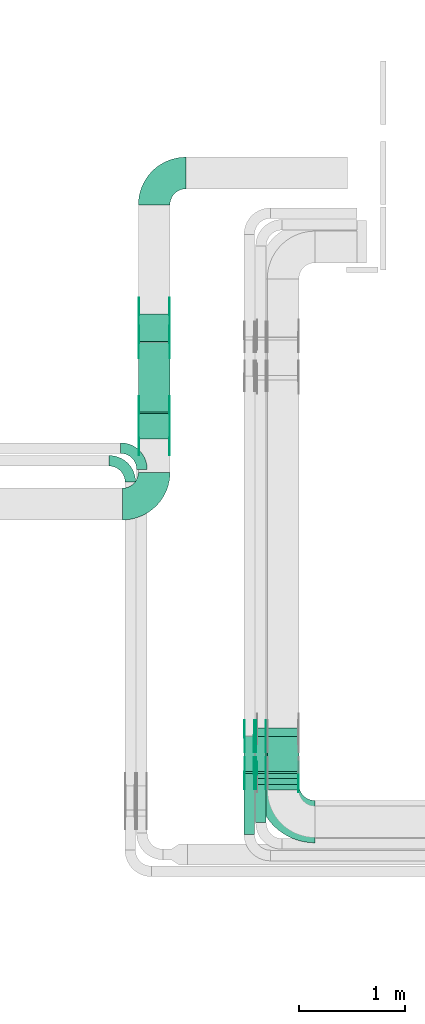
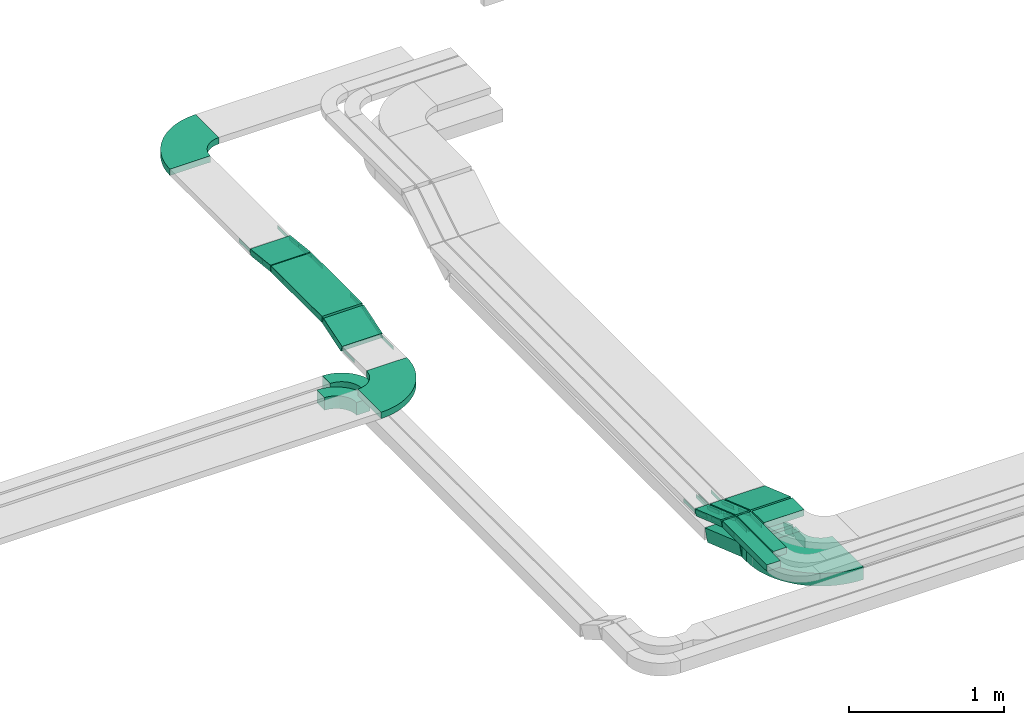
# One storey, part 7 of 28: 40 flow fittings, 11 flow segments.
"""IFC2X3 building model written with IfcOpenShell, lengths in millimetres."""

from ifc_helpers import new_model, entity, si_unit, converted_unit, derived_unit, direction, frame, frame_2d, origin, origin_2d_with_axis, place, context, subcontext, project, spatial, polyline, circle_curve, parameter, trimmed, segment, composite_curve, rectangle, outline, extrude, source, transform, mapped, material, type_object, type_shapes, element, save


model = new_model("IFC2X3")

# Units and contexts
model_context = context("Model", 3, precision=0.01, world=origin(), true_north=direction((6.12303176911189e-17, 1.0)))
body_context = subcontext(model_context, "Body", "Model", "MODEL_VIEW")
ifc_project = project(units=[si_unit("LENGTHUNIT", "METRE", prefix="MILLI"), si_unit("AREAUNIT", "SQUARE_METRE"), si_unit("VOLUMEUNIT", "CUBIC_METRE"), converted_unit("PLANEANGLEUNIT", "DEGREE", entity("IfcRatioMeasure", 0.0174532925199433), si_unit("PLANEANGLEUNIT", "RADIAN"), dimensions=[0, 0, 0, 0, 0, 0, 0]), si_unit("MASSUNIT", "GRAM", prefix="KILO"), derived_unit("MASSDENSITYUNIT", [(si_unit("MASSUNIT", "GRAM", prefix="KILO"), 1), (si_unit("LENGTHUNIT", "METRE"), -3)]), derived_unit("MOMENTOFINERTIAUNIT", [(si_unit("LENGTHUNIT", "METRE"), 4)]), si_unit("TIMEUNIT", "SECOND"), si_unit("FREQUENCYUNIT", "HERTZ"), si_unit("THERMODYNAMICTEMPERATUREUNIT", "DEGREE_CELSIUS"), derived_unit("THERMALTRANSMITTANCEUNIT", [(si_unit("MASSUNIT", "GRAM", prefix="KILO"), 1), (si_unit("THERMODYNAMICTEMPERATUREUNIT", "KELVIN"), -1), (si_unit("TIMEUNIT", "SECOND"), -3)]), derived_unit("VOLUMETRICFLOWRATEUNIT", [(si_unit("LENGTHUNIT", "METRE"), 3), (si_unit("TIMEUNIT", "SECOND"), -1)]), derived_unit("MASSFLOWRATEUNIT", [(si_unit("MASSUNIT", "GRAM", prefix="KILO"), 1), (si_unit("TIMEUNIT", "SECOND"), -1)]), derived_unit("ROTATIONALFREQUENCYUNIT", [(si_unit("TIMEUNIT", "SECOND"), -1)]), si_unit("ELECTRICCURRENTUNIT", "AMPERE"), si_unit("ELECTRICVOLTAGEUNIT", "VOLT"), si_unit("POWERUNIT", "WATT"), si_unit("FORCEUNIT", "NEWTON", prefix="KILO"), si_unit("ILLUMINANCEUNIT", "LUX"), si_unit("LUMINOUSFLUXUNIT", "LUMEN"), si_unit("LUMINOUSINTENSITYUNIT", "CANDELA"), derived_unit("USERDEFINED", [(si_unit("MASSUNIT", "GRAM", prefix="KILO"), -1), (si_unit("LENGTHUNIT", "METRE"), -2), (si_unit("TIMEUNIT", "SECOND"), 3), (si_unit("LUMINOUSFLUXUNIT", "LUMEN"), 1)]), derived_unit("LINEARVELOCITYUNIT", [(si_unit("LENGTHUNIT", "METRE"), 1), (si_unit("TIMEUNIT", "SECOND"), -1)]), si_unit("PRESSUREUNIT", "PASCAL"), derived_unit("USERDEFINED", [(si_unit("LENGTHUNIT", "METRE"), -2), (si_unit("MASSUNIT", "GRAM", prefix="KILO"), 1), (si_unit("TIMEUNIT", "SECOND"), -2)]), derived_unit("LINEARFORCEUNIT", [(si_unit("MASSUNIT", "GRAM", prefix="KILO"), 1), (si_unit("LENGTHUNIT", "METRE"), 1), (si_unit("TIMEUNIT", "SECOND"), -2), (si_unit("LENGTHUNIT", "METRE"), -1)]), derived_unit("PLANARFORCEUNIT", [(si_unit("MASSUNIT", "GRAM", prefix="KILO"), 1), (si_unit("LENGTHUNIT", "METRE"), 1), (si_unit("TIMEUNIT", "SECOND"), -2), (si_unit("LENGTHUNIT", "METRE"), -2)])], contexts=[model_context])

# Site, building, storey
site_placement = place(None, frame((0.0, -0.00077364408347762, 0.0)))
site = spatial("IfcSite", under=ifc_project, at=site_placement, CompositionType="ELEMENT")
building_placement = place(site_placement, origin())
building = spatial("IfcBuilding", under=site, at=building_placement, CompositionType="ELEMENT")
storey_placement = place(building_placement, origin())
storey = spatial("IfcBuildingStorey", under=building, at=storey_placement, CompositionType="ELEMENT", Elevation=0.0)

# Flow segments
cable_carrier_segment_type = type_object("IfcCableCarrierSegmentType", PredefinedType="CABLETRAYSEGMENT")
flow_segment_1_placement = place(storey_placement, frame((14179.9969238281, 12648.7323497056, 3230.0)))
element("IfcFlowSegment", 1, at=flow_segment_1_placement, inside=storey, type_object=cable_carrier_segment_type, context=body_context, shape_type="SweptSolid", body=[
    extrude(rectangle(XDim=656.864231681176, YDim=300.000000000001, at=frame_2d((1.10844666778576e-12, 0.0), x_axis=(1.0, 0.0))), frame((150.0, 328.432115840592, 0.0), z_axis=(0.0, 0.0, 1.0), x_axis=(0.0, -1.0, 0.0)), (0.0, 0.0, 1.0), 50.0000000000011),
])
flow_segment_2_placement = place(storey_placement, frame((15399.9969238281, 9071.00006103511, 3350.0)))
element("IfcFlowSegment", 2, at=flow_segment_2_placement, inside=storey, type_object=cable_carrier_segment_type, context=body_context, shape_type="SweptSolid", body=[
    extrude(rectangle(XDim=153.10288471087, YDim=300.000000000001, at=frame_2d((-5.47117906535277e-13, 2.17426077142591e-12), x_axis=(1.0, 0.0))), frame((150.0, 76.5514423554497, 0.0), z_axis=(0.0, 0.0, 1.0), x_axis=(0.0, 1.0, 0.0)), (0.0, 0.0, 1.0), 49.9999999999995),
])
flow_segment_3_placement = place(storey_placement, frame((15289.9969238281, 8761.00006103504, 3350.0)))
element("IfcFlowSegment", 3, at=flow_segment_3_placement, inside=storey, type_object=cable_carrier_segment_type, context=body_context, shape_type="SweptSolid", body=[
    extrude(rectangle(XDim=463.102884710998, YDim=99.9999999999989, at=frame_2d((5.40012479177676e-13, -1.08357767203415e-12), x_axis=(1.0, 0.0))), frame((50.0, 231.551442355504, 0.0), z_axis=(0.0, 0.0, 1.0), x_axis=(0.0, 1.0, 0.0)), (0.0, 0.0, 1.0), 49.9999999999989),
])
flow_segment_4_placement = place(storey_placement, frame((15179.9969238281, 8651.00006103517, 3350.0)))
element("IfcFlowSegment", 4, at=flow_segment_4_placement, inside=storey, type_object=cable_carrier_segment_type, context=body_context, shape_type="SweptSolid", body=[
    extrude(rectangle(XDim=573.102884710878, YDim=99.9999999999989, at=frame_2d((5.40012479177676e-13, -1.08357767203415e-12), x_axis=(1.0, 0.0))), frame((50.0, 286.551442355443, 0.0), z_axis=(0.0, 0.0, 1.0), x_axis=(0.0, 1.0, 0.0)), (0.0, 0.0, 1.0), 50.0000000000005),
])
flow_segment_5_placement = place(storey_placement, frame((15399.9969238281, 9227.36096915016, 3233.32268333908)))
element("IfcFlowSegment", 5, at=flow_segment_5_placement, inside=storey, type_object=cable_carrier_segment_type, context=body_context, shape_type="SweptSolid", body=[
    extrude(rectangle(XDim=50.0000000000003, YDim=353.648950469399, at=frame_2d((4.2632564145606e-13, 4.33431068813661e-13), x_axis=(0.0, 1.0))), frame((0.0, 175.22871974184, 81.6773166623103), z_axis=(1.0, 0.0, 0.0), x_axis=(0.0, 0.944549723773447, -0.328368420100814)), (0.0, 0.0, 1.0), 299.999999999999),
])
flow_segment_6_placement = place(storey_placement, frame((15289.9969238281, 9227.36096915014, 3233.32268333903)))
element("IfcFlowSegment", 6, at=flow_segment_6_placement, inside=storey, type_object=cable_carrier_segment_type, context=body_context, shape_type="SweptSolid", body=[
    extrude(rectangle(XDim=50.0000000000002, YDim=353.6489504697, at=frame_2d((6.11066752753686e-13, -7.8159700933611e-14), x_axis=(0.0, 1.0))), frame((0.0, 175.228719741989, 81.6773166623298), z_axis=(1.0, 0.0, 0.0), x_axis=(0.0, 0.944549723773509, -0.328368420100635)), (0.0, 0.0, 1.0), 100.000000000001),
])
flow_segment_7_placement = place(storey_placement, frame((15179.9969238281, 9227.36096915014, 3233.32268333904)))
element("IfcFlowSegment", 7, at=flow_segment_7_placement, inside=storey, type_object=cable_carrier_segment_type, context=body_context, shape_type="SweptSolid", body=[
    extrude(rectangle(XDim=50.0000000000002, YDim=353.648950469667, at=frame_2d((8.5265128291212e-14, -2.55795384873636e-13), x_axis=(0.0, 1.0))), frame((0.0, 175.228719741974, 81.6773166623243), z_axis=(1.0, 0.0, 0.0), x_axis=(0.0, 0.944549723773509, -0.328368420100635)), (0.0, 0.0, 1.0), 100.000000000001),
])
flow_segment_8_placement = place(storey_placement, frame((15299.9969238281, 9121.0000610352, 3100.0)))
element("IfcFlowSegment", 8, at=flow_segment_8_placement, inside=storey, type_object=cable_carrier_segment_type, context=body_context, shape_type="SweptSolid", body=[
    extrude(rectangle(XDim=58.881233599423, YDim=400.0, at=origin_2d_with_axis()), frame((200.0, 29.4406167997267, 0.0), z_axis=(0.0, 0.0, 1.0), x_axis=(0.0, 1.0, 0.0)), (0.0, 0.0, 1.0), 100.0),
])
flow_segment_9_placement = place(storey_placement, frame((15299.9969238281, 9183.1393180388, 2946.09519714764)))
element("IfcFlowSegment", 9, at=flow_segment_9_placement, inside=storey, type_object=cable_carrier_segment_type, context=body_context, shape_type="SweptSolid", body=[
    extrude(rectangle(XDim=100.0, YDim=467.020041940275, at=frame_2d((-5.11590769747272e-13, -1.77635683940025e-13), x_axis=(0.0, 1.0))), frame((0.0, 236.980246810732, 123.904802852354), z_axis=(1.0, 0.0, 0.0), x_axis=(0.0, 0.944549723773432, -0.328368420100856)), (0.0, 0.0, 1.0), 400.0),
])
flow_segment_10_placement = place(storey_placement, frame((14179.9969238281, 13308.0381311058, 3200.4514679737)))
element("IfcFlowSegment", 10, at=flow_segment_10_placement, inside=storey, type_object=cable_carrier_segment_type, context=body_context, shape_type="SweptSolid", body=[
    extrude(rectangle(XDim=49.9999999999999, YDim=262.697627872475, at=frame_2d((0.0, 0.0), x_axis=(0.0, 1.0))), frame((0.0, 133.321978545694, 39.5485320262596), z_axis=(1.0, 0.0, 0.0), x_axis=(0.0, 0.993712801032518, -0.111959229472644)), (0.0, 0.0, 1.0), 300.000000000001),
])
flow_segment_11_placement = place(storey_placement, frame((14179.9969238282, 12389.7379245841, 3152.85082961137)))
element("IfcFlowSegment", 11, at=flow_segment_11_placement, inside=storey, type_object=cable_carrier_segment_type, context=body_context, shape_type="SweptSolid", body=[
    extrude(rectangle(XDim=49.9999999999991, YDim=252.566107987127, at=frame_2d((8.5265128291212e-14, 2.59348098552437e-13), x_axis=(0.0, 1.0))), frame((0.0, 127.913773855075, 62.149170388603), z_axis=(1.0, 0.0, 0.0), x_axis=(0.0, -0.952827460672093, -0.303512487698893)), (0.0, 0.0, 1.0), 300.000000000003),
])

# Flow fittings
ifc_material_1 = material(Name="G")
cable_carrier_fitting_type_1 = type_object("IfcCableCarrierFittingType", PredefinedType="NOTDEFINED", material=ifc_material_1)
shared_shape_1 = source(origin(), body_context, "Body", "SweptSolid", [
    extrude(outline(composite_curve([segment(trimmed(circle_curve(frame_2d((-44.5901162790698, 0.0), x_axis=(1.0, 0.0)), 12.5), [parameter(90.0000000000007)], [parameter(270.0)], True, "PARAMETER"), True, "CONTINUOUS"), segment(polyline([(-44.5901162790697, -12.5), (-33.0901162790698, -12.5)]), True, "CONTINUOUS"), segment(polyline([(-33.0901162790698, -12.5), (-31.2296511627907, -14.5)]), True, "CONTINUOUS"), segment(polyline([(-31.2296511627907, -14.5), (108.90988372093, -14.5)]), True, "CONTINUOUS"), segment(polyline([(108.90988372093, -14.5), (108.90988372093, 14.5)]), True, "CONTINUOUS"), segment(polyline([(108.90988372093, 14.5), (-31.2296511627907, 14.5)]), True, "CONTINUOUS"), segment(polyline([(-31.2296511627907, 14.5), (-33.0901162790698, 12.5)]), True, "CONTINUOUS"), segment(polyline([(-33.0901162790698, 12.5), (-44.5901162790699, 12.5)]), True, "CONTINUOUS")], self_intersect=False)), frame((44.5901162790698, 0.0, 0.0), z_axis=(0.0, 0.0, -1.0), x_axis=(1.0, 0.0, 0.0)), (0.0, 0.0, -1.0), 2.0),
])
type_shapes(cable_carrier_fitting_type_1, [shared_shape_1])
for number, where, z_axis, x_axis in (
    (12, (15385.4569238383, 9230.00006103519, 3375.0), (1.0, 0.0, 0.0), (0.0, -1.0, 0.0)),
    (13, (15275.4569238383, 9230.00006103519, 3375.0), (1.0, 0.0, 0.0), (0.0, -1.0, 0.0)),
    (14, (15385.4569238383, 9575.17931674909, 3255.0), (1.0, 0.0, 0.0), (0.0, 1.0, 0.0)),
    (15, (15275.4569238383, 9575.17931674904, 3255.0), (1.0, 0.0, 0.0), (0.0, 1.0, 0.0)),
    (16, (14184.536923818, 13574.4951096481, 3225.0), (-1.0, 0.0, 0.0), (0.0, -0.993712801032518, 0.111959229472643)),
    (17, (14475.4569238383, 13308.2251096548, 3255.0), (1.0, 0.0, 0.0), (0.0, -1.0, 0.0)),
    (18, (14475.4569238383, 12643.2251096548, 3255.0), (1.0, 0.0, 0.0), (0.0, -0.952827460672923, -0.303512487696289)),
    (19, (14475.4569238383, 12392.0782872236, 3175.0), (1.0, 0.0, 0.0), (0.0, 0.952827460672923, 0.303512487696289)),
):
    element("IfcFlowFitting", number, at=place(storey_placement, frame(where, z_axis=z_axis, x_axis=x_axis)), inside=storey, type_object=cable_carrier_fitting_type_1, material=ifc_material_1, context=body_context, shape_type="MappedRepresentation", body=[
        mapped(shared_shape_1, transform((0.0, 0.0, 0.0), scale=1.0)),
    ])
cable_carrier_fitting_type_2 = type_object("IfcCableCarrierFittingType", PredefinedType="NOTDEFINED", material=ifc_material_1)
shared_shape_2 = source(origin(), body_context, "Body", "SweptSolid", [
    extrude(outline(composite_curve([segment(trimmed(circle_curve(frame_2d((-44.5901162790697, 0.0), x_axis=(1.0, 0.0)), 12.5), [parameter(90.0000000000007)], [parameter(270.0)], True, "PARAMETER"), True, "CONTINUOUS"), segment(polyline([(-44.5901162790697, -12.5), (-33.0901162790697, -12.5)]), True, "CONTINUOUS"), segment(polyline([(-33.0901162790697, -12.5), (-31.2296511627907, -14.5)]), True, "CONTINUOUS"), segment(polyline([(-31.2296511627907, -14.5), (108.90988372093, -14.5)]), True, "CONTINUOUS"), segment(polyline([(108.90988372093, -14.5), (108.90988372093, 14.5)]), True, "CONTINUOUS"), segment(polyline([(108.90988372093, 14.5), (-31.2296511627907, 14.5)]), True, "CONTINUOUS"), segment(polyline([(-31.2296511627907, 14.5), (-33.0901162790698, 12.5)]), True, "CONTINUOUS"), segment(polyline([(-33.0901162790698, 12.5), (-44.5901162790699, 12.5)]), True, "CONTINUOUS")], self_intersect=False)), frame((44.5901162790697, 0.0, 0.0)), (0.0, 0.0, 1.0), 2.0),
])
type_shapes(cable_carrier_fitting_type_2, [shared_shape_2])
for number, where, z_axis, x_axis in (
    (20, (15294.536923818, 9230.00006103519, 3375.0), (-1.0, 0.0, 0.0), (0.0, -1.0, 0.0)),
    (21, (15184.536923818, 9230.00006103519, 3375.0), (-1.0, 0.0, 0.0), (0.0, -1.0, 0.0)),
    (22, (15294.536923818, 9575.17931674908, 3255.0), (-1.0, 0.0, 0.0), (0.0, 1.0, 0.0)),
    (23, (15184.536923818, 9575.17931674904, 3255.0), (-1.0, 0.0, 0.0), (0.0, 1.0, 0.0)),
    (24, (14475.4569238383, 13574.4951096482, 3225.0), (1.0, 0.0, 0.0), (0.0, -0.993712801032518, 0.111959229472643)),
    (25, (14184.536923818, 13308.2251096548, 3255.0), (-1.0, 0.0, 0.0), (0.0, -1.0, 0.0)),
    (26, (14184.536923818, 12643.2251096548, 3255.0), (-1.0, 0.0, 0.0), (0.0, -0.952827460672923, -0.303512487696289)),
    (27, (14184.536923818, 12392.0782872236, 3175.0), (-1.0, 0.0, 0.0), (0.0, 0.952827460672923, 0.303512487696289)),
):
    element("IfcFlowFitting", number, at=place(storey_placement, frame(where, z_axis=z_axis, x_axis=x_axis)), inside=storey, type_object=cable_carrier_fitting_type_2, material=ifc_material_1, context=body_context, shape_type="MappedRepresentation", body=[
        mapped(shared_shape_2, transform((0.0, 0.0, 0.0), scale=1.0)),
    ])
cable_carrier_fitting_type_3 = type_object("IfcCableCarrierFittingType", PredefinedType="NOTDEFINED", material=ifc_material_1)
shared_shape_3 = source(origin(), body_context, "Body", "SweptSolid", [
    extrude(outline(composite_curve([segment(trimmed(circle_curve(frame_2d((-44.5901162790698, 0.0), x_axis=(1.0, 0.0)), 12.5), [parameter(90.0000000000007)], [parameter(270.0)], True, "PARAMETER"), True, "CONTINUOUS"), segment(polyline([(-44.5901162790697, -12.5), (-33.0901162790698, -12.5)]), True, "CONTINUOUS"), segment(polyline([(-33.0901162790698, -12.5), (-31.2296511627907, -14.5)]), True, "CONTINUOUS"), segment(polyline([(-31.2296511627907, -14.5), (108.90988372093, -14.5)]), True, "CONTINUOUS"), segment(polyline([(108.90988372093, -14.5), (108.90988372093, 14.5)]), True, "CONTINUOUS"), segment(polyline([(108.90988372093, 14.5), (-31.2296511627907, 14.5)]), True, "CONTINUOUS"), segment(polyline([(-31.2296511627907, 14.5), (-33.0901162790698, 12.5)]), True, "CONTINUOUS"), segment(polyline([(-33.0901162790698, 12.5), (-44.5901162790699, 12.5)]), True, "CONTINUOUS")], self_intersect=False)), frame((44.5901162790698, 0.0, 0.0), z_axis=(0.0, 0.0, -1.0), x_axis=(1.0, 0.0, 0.0)), (0.0, 0.0, -1.0), 2.0),
])
type_shapes(cable_carrier_fitting_type_3, [shared_shape_3])
for number, where, z_axis, x_axis in (
    (28, (15296.536923818, 9230.00006103517, 3375.0), (-1.0, 0.0, 0.0), (0.0, 0.94454972377348, -0.328368420100718)),
    (29, (15186.536923818, 9230.00006103517, 3375.0), (-1.0, 0.0, 0.0), (0.0, 0.94454972377348, -0.328368420100718)),
    (30, (15296.536923818, 9575.1793167491, 3255.0), (-1.0, 0.0, 0.0), (0.0, -0.944549723773511, 0.328368420100629)),
    (31, (15186.536923818, 9575.17931674905, 3255.0), (-1.0, 0.0, 0.0), (0.0, -0.944549723773511, 0.328368420100629)),
    (32, (14473.4569238383, 13574.4951096481, 3225.0), (1.0, 0.0, 0.0), (0.0, 1.0, 0.0)),
    (33, (14186.536923818, 13308.2251096548, 3255.0), (-1.0, 0.0, 0.0), (0.0, 0.993712801032518, -0.111959229472637)),
    (34, (14186.536923818, 12643.2251096548, 3255.0), (-1.0, 0.0, 0.0), (0.0, 1.0, 0.0)),
    (35, (14186.536923818, 12392.0782872236, 3175.0), (-1.0, 0.0, 0.0), (0.0, -1.0, 0.0)),
):
    element("IfcFlowFitting", number, at=place(storey_placement, frame(where, z_axis=z_axis, x_axis=x_axis)), inside=storey, type_object=cable_carrier_fitting_type_3, material=ifc_material_1, context=body_context, shape_type="MappedRepresentation", body=[
        mapped(shared_shape_3, transform((0.0, 0.0, 0.0), scale=1.0)),
    ])
cable_carrier_fitting_type_4 = type_object("IfcCableCarrierFittingType", PredefinedType="NOTDEFINED", material=ifc_material_1)
shared_shape_4 = source(origin(), body_context, "Body", "SweptSolid", [
    extrude(outline(composite_curve([segment(trimmed(circle_curve(frame_2d((-44.5901162790697, 0.0), x_axis=(1.0, 0.0)), 12.5), [parameter(90.0000000000007)], [parameter(270.0)], True, "PARAMETER"), True, "CONTINUOUS"), segment(polyline([(-44.5901162790697, -12.5), (-33.0901162790697, -12.5)]), True, "CONTINUOUS"), segment(polyline([(-33.0901162790697, -12.5), (-31.2296511627907, -14.5)]), True, "CONTINUOUS"), segment(polyline([(-31.2296511627907, -14.5), (108.90988372093, -14.5)]), True, "CONTINUOUS"), segment(polyline([(108.90988372093, -14.5), (108.90988372093, 14.5)]), True, "CONTINUOUS"), segment(polyline([(108.90988372093, 14.5), (-31.2296511627907, 14.5)]), True, "CONTINUOUS"), segment(polyline([(-31.2296511627907, 14.5), (-33.0901162790698, 12.5)]), True, "CONTINUOUS"), segment(polyline([(-33.0901162790698, 12.5), (-44.5901162790699, 12.5)]), True, "CONTINUOUS")], self_intersect=False)), frame((44.5901162790697, 0.0, 0.0)), (0.0, 0.0, 1.0), 2.0),
])
type_shapes(cable_carrier_fitting_type_4, [shared_shape_4])
for number, where, z_axis, x_axis in (
    (36, (15383.4569238383, 9230.00006103517, 3375.0), (1.0, 0.0, 0.0), (0.0, 0.94454972377348, -0.328368420100718)),
    (37, (15273.4569238383, 9230.00006103517, 3375.0), (1.0, 0.0, 0.0), (0.0, 0.94454972377348, -0.328368420100718)),
    (38, (15383.4569238383, 9575.1793167491, 3255.0), (1.0, 0.0, 0.0), (0.0, -0.944549723773511, 0.328368420100629)),
    (39, (15273.4569238383, 9575.17931674905, 3255.0), (1.0, 0.0, 0.0), (0.0, -0.944549723773511, 0.328368420100629)),
    (40, (14186.536923818, 13574.4951096481, 3225.0), (-1.0, 0.0, 0.0), (0.0, 1.0, 0.0)),
    (41, (14473.4569238383, 13308.2251096548, 3255.0), (1.0, 0.0, 0.0), (0.0, 0.993712801032518, -0.111959229472637)),
    (42, (14473.4569238383, 12643.2251096548, 3255.0), (1.0, 0.0, 0.0), (0.0, 1.0, 0.0)),
    (43, (14473.4569238383, 12392.0782872236, 3175.0), (1.0, 0.0, 0.0), (0.0, -1.0, 0.0)),
):
    element("IfcFlowFitting", number, at=place(storey_placement, frame(where, z_axis=z_axis, x_axis=x_axis)), inside=storey, type_object=cable_carrier_fitting_type_4, material=ifc_material_1, context=body_context, shape_type="MappedRepresentation", body=[
        mapped(shared_shape_4, transform((0.0, 0.0, 0.0), scale=1.0)),
    ])
cable_carrier_fitting_type_5 = type_object("IfcCableCarrierFittingType", PredefinedType="NOTDEFINED", material=ifc_material_1)
shared_shape_5 = source(origin(), body_context, "Body", "SweptSolid", [
    extrude(outline(composite_curve([segment(trimmed(circle_curve(frame_2d((-41.4651162790697, 0.0), x_axis=(1.0, 0.0)), 25.0), [parameter(90.0000000000007)], [parameter(270.0)], True, "PARAMETER"), True, "CONTINUOUS"), segment(polyline([(-41.4651162790697, -25.0), (-29.9651162790697, -25.0)]), True, "CONTINUOUS"), segment(polyline([(-29.9651162790697, -25.0), (-28.1046511627907, -38.5)]), True, "CONTINUOUS"), segment(polyline([(-28.1046511627907, -38.5), (99.5348837209303, -38.5)]), True, "CONTINUOUS"), segment(polyline([(99.5348837209303, -38.5), (99.5348837209303, 38.5)]), True, "CONTINUOUS"), segment(polyline([(99.5348837209303, 38.5), (-28.1046511627907, 38.5)]), True, "CONTINUOUS"), segment(polyline([(-28.1046511627907, 38.5), (-29.9651162790697, 25.0)]), True, "CONTINUOUS"), segment(polyline([(-29.9651162790697, 25.0), (-41.46511627907, 25.0)]), True, "CONTINUOUS")], self_intersect=False)), frame((41.4651162790697, 0.0, 0.0), z_axis=(0.0, 0.0, -1.0), x_axis=(1.0, 0.0, 0.0)), (0.0, 0.0, -1.0), 2.0),
])
type_shapes(cable_carrier_fitting_type_5, [shared_shape_5])
flow_fitting_1_placement = place(storey_placement, frame((15304.536923818, 9190.00006103523, 3150.0), z_axis=(-1.0, 0.0, 0.0), x_axis=(0.0, 0.944549723773443, -0.328368420100826)))
element("IfcFlowFitting", 44, at=flow_fitting_1_placement, inside=storey, type_object=cable_carrier_fitting_type_5, material=ifc_material_1, context=body_context, shape_type="MappedRepresentation", body=[
    mapped(shared_shape_5, transform((0.0, 0.0, 0.0), scale=1.0)),
])
cable_carrier_fitting_type_6 = type_object("IfcCableCarrierFittingType", PredefinedType="NOTDEFINED", material=ifc_material_1)
shared_shape_6 = source(origin(), body_context, "Body", "SweptSolid", [
    extrude(outline(composite_curve([segment(trimmed(circle_curve(frame_2d((-41.4651162790697, 0.0), x_axis=(1.0, 0.0)), 25.0), [parameter(90.0000000000007)], [parameter(270.0)], True, "PARAMETER"), True, "CONTINUOUS"), segment(polyline([(-41.4651162790697, -25.0), (-29.9651162790697, -25.0)]), True, "CONTINUOUS"), segment(polyline([(-29.9651162790697, -25.0), (-28.1046511627907, -38.5)]), True, "CONTINUOUS"), segment(polyline([(-28.1046511627907, -38.5), (99.5348837209303, -38.5)]), True, "CONTINUOUS"), segment(polyline([(99.5348837209303, -38.5), (99.5348837209303, 38.5)]), True, "CONTINUOUS"), segment(polyline([(99.5348837209303, 38.5), (-28.1046511627907, 38.5)]), True, "CONTINUOUS"), segment(polyline([(-28.1046511627907, 38.5), (-29.9651162790697, 25.0)]), True, "CONTINUOUS"), segment(polyline([(-29.9651162790697, 25.0), (-41.46511627907, 25.0)]), True, "CONTINUOUS")], self_intersect=False)), frame((41.4651162790697, 0.0, 0.0)), (0.0, 0.0, 1.0), 2.0),
])
type_shapes(cable_carrier_fitting_type_6, [shared_shape_6])
flow_fitting_2_placement = place(storey_placement, frame((15695.4569238383, 9190.00006103523, 3150.0), z_axis=(1.0, 0.0, 0.0), x_axis=(0.0, 0.944549723773443, -0.328368420100826)))
element("IfcFlowFitting", 45, at=flow_fitting_2_placement, inside=storey, type_object=cable_carrier_fitting_type_6, material=ifc_material_1, context=body_context, shape_type="MappedRepresentation", body=[
    mapped(shared_shape_6, transform((0.0, 0.0, 0.0), scale=1.0)),
])
cable_carrier_fitting_type_7 = type_object("IfcCableCarrierFittingType", PredefinedType="NOTDEFINED", material=ifc_material_1)
shared_shape_7 = source(origin(), body_context, "Body", "SweptSolid", [
    extrude(outline(composite_curve([segment(trimmed(circle_curve(frame_2d((-41.4651162790697, 0.0), x_axis=(1.0, 0.0)), 25.0), [parameter(90.0000000000007)], [parameter(270.0)], True, "PARAMETER"), True, "CONTINUOUS"), segment(polyline([(-41.4651162790697, -25.0), (-29.9651162790697, -25.0)]), True, "CONTINUOUS"), segment(polyline([(-29.9651162790697, -25.0), (-28.1046511627907, -38.5)]), True, "CONTINUOUS"), segment(polyline([(-28.1046511627907, -38.5), (99.5348837209303, -38.5)]), True, "CONTINUOUS"), segment(polyline([(99.5348837209303, -38.5), (99.5348837209303, 38.5)]), True, "CONTINUOUS"), segment(polyline([(99.5348837209303, 38.5), (-28.1046511627907, 38.5)]), True, "CONTINUOUS"), segment(polyline([(-28.1046511627907, 38.5), (-29.9651162790697, 25.0)]), True, "CONTINUOUS"), segment(polyline([(-29.9651162790697, 25.0), (-41.46511627907, 25.0)]), True, "CONTINUOUS")], self_intersect=False)), frame((41.4651162790697, 0.0, 0.0), z_axis=(0.0, 0.0, -1.0), x_axis=(1.0, 0.0, 0.0)), (0.0, 0.0, -1.0), 2.0),
])
type_shapes(cable_carrier_fitting_type_7, [shared_shape_7])
flow_fitting_3_placement = place(storey_placement, frame((15693.4569238383, 9190.00006103524, 3150.0), z_axis=(1.0, 0.0, 0.0), x_axis=(0.0, -1.0, 0.0)))
element("IfcFlowFitting", 46, at=flow_fitting_3_placement, inside=storey, type_object=cable_carrier_fitting_type_7, material=ifc_material_1, context=body_context, shape_type="MappedRepresentation", body=[
    mapped(shared_shape_7, transform((0.0, 0.0, 0.0), scale=1.0)),
])
ifc_material_2 = material()
cable_carrier_fitting_type_8 = type_object("IfcCableCarrierFittingType", Name="470_DKC_S5_Variable Angle Elbow 0-45:-", PredefinedType="NOTDEFINED", material=ifc_material_2)
shared_shape_8 = source(origin(), body_context, "Body", "SweptSolid", [
    extrude(outline(composite_curve([segment(polyline([(-150.749999999996, -300.250000000003), (-149.749999999994, -300.250000000003)]), True, "CONTINUOUS"), segment(trimmed(circle_curve(frame_2d((-149.750000000002, 149.749999999997), x_axis=(0.0, -1.0)), 450.0), [parameter(0.0)], [parameter(90.0000000000001)], True, "PARAMETER"), True, "CONTINUOUS"), segment(polyline([(300.249999999997, 149.750000000005), (300.249999999997, 150.750000000004)]), True, "CONTINUOUS"), segment(polyline([(300.249999999997, 150.750000000003), (0.249999999997449, 150.750000000002)]), True, "CONTINUOUS"), segment(polyline([(0.249999999997449, 150.750000000002), (0.249999999997438, 149.75)]), True, "CONTINUOUS"), segment(trimmed(circle_curve(frame_2d((-149.750000000002, 149.749999999997), x_axis=(0.0, -1.0)), 150.0), [parameter(0.0)], [parameter(90.0000000000001)], True, "PARAMETER"), False, "CONTINUOUS"), segment(polyline([(-149.749999999999, -0.250000000002818), (-150.750000000001, -0.250000000002835)]), True, "CONTINUOUS"), segment(polyline([(-150.750000000001, -0.250000000002835), (-150.749999999996, -300.250000000003)]), True, "CONTINUOUS")], self_intersect=False)), frame((-150.249999999991, 150.249999999992, -25.0)), (0.0, 0.0, 1.0), 49.9999999999974),
])
type_shapes(cable_carrier_fitting_type_8, [shared_shape_8])
flow_fitting_4_placement = place(storey_placement, frame((14329.9969238281, 14907.6093717678, 3225.0), z_axis=(0.0, 0.0, 1.0), x_axis=(-1.0, 0.0, 0.0)))
element("IfcFlowFitting", 47, at=flow_fitting_4_placement, inside=storey, type_object=cable_carrier_fitting_type_8, material=ifc_material_2, Name="470_DKC_S5_Variable Angle Elbow 0-45:-", ObjectType="470_DKC_S5_Variable Angle Elbow 0-45:-", context=body_context, shape_type="MappedRepresentation", body=[
    mapped(shared_shape_8, transform((0.0, 0.0, 0.0), scale=1.0)),
])
flow_fitting_5_placement = place(storey_placement, frame((14329.9969238282, 11775.2683846925, 3175.0)))
element("IfcFlowFitting", 48, at=flow_fitting_5_placement, inside=storey, type_object=cable_carrier_fitting_type_8, material=ifc_material_2, Name="470_DKC_S5_Variable Angle Elbow 0-45:-", ObjectType="470_DKC_S5_Variable Angle Elbow 0-45:-", context=body_context, shape_type="MappedRepresentation", body=[
    mapped(shared_shape_8, transform((0.0, 0.0, 0.0), scale=1.0)),
])
cable_carrier_fitting_type_9 = type_object("IfcCableCarrierFittingType", Name="470_DKC_S5_Variable Angle Elbow 0-45:-", PredefinedType="NOTDEFINED", material=ifc_material_2)
shared_shape_9 = source(origin(), body_context, "Body", "SweptSolid", [
    extrude(outline(composite_curve([segment(polyline([(-175.750000000001, -375.25), (-174.749999999999, -375.25)]), True, "CONTINUOUS"), segment(trimmed(circle_curve(frame_2d((-174.75, 174.75), x_axis=(0.0, -1.0)), 550.0), [parameter(0.0)], [parameter(90.0)], True, "PARAMETER"), True, "CONTINUOUS"), segment(polyline([(375.25, 174.75), (375.25, 175.749999999997)]), True, "CONTINUOUS"), segment(polyline([(375.25, 175.749999999997), (-24.7500000000001, 175.750000000002)]), True, "CONTINUOUS"), segment(polyline([(-24.7500000000001, 175.750000000002), (-24.75, 174.75)]), True, "CONTINUOUS"), segment(trimmed(circle_curve(frame_2d((-174.75, 174.75), x_axis=(0.0, -1.0)), 150.0), [parameter(0.0)], [parameter(90.0)], True, "PARAMETER"), False, "CONTINUOUS"), segment(polyline([(-174.749999999999, 24.7499999999999), (-175.750000000001, 24.7499999999999)]), True, "CONTINUOUS"), segment(polyline([(-175.750000000001, 24.7499999999999), (-175.750000000001, -375.25)]), True, "CONTINUOUS")], self_intersect=False)), frame((-175.24999999999, 175.249999999992, -50.0)), (0.0, 0.0, 1.0), 99.9999999999956),
])
type_shapes(cable_carrier_fitting_type_9, [shared_shape_9])
flow_fitting_6_placement = place(storey_placement, frame((15499.9969238281, 8770.00006103523, 3150.0), z_axis=(0.0, 0.0, 1.0), x_axis=(0.0, -1.0, 0.0)))
element("IfcFlowFitting", 49, at=flow_fitting_6_placement, inside=storey, type_object=cable_carrier_fitting_type_9, material=ifc_material_2, Name="470_DKC_S5_Variable Angle Elbow 0-45:-", ObjectType="470_DKC_S5_Variable Angle Elbow 0-45:-", context=body_context, shape_type="MappedRepresentation", body=[
    mapped(shared_shape_9, transform((0.0, 0.0, 0.0), scale=1.0)),
])
cable_carrier_fitting_type_10 = type_object("IfcCableCarrierFittingType", Name="470_DKC_S5_Variable Angle Elbow 0-45:-", PredefinedType="NOTDEFINED", material=ifc_material_2)
shared_shape_10 = source(origin(), body_context, "Body", "SweptSolid", [
    extrude(outline(composite_curve([segment(polyline([(-100.749999999999, -150.250000000001), (-99.7499999999981, -150.250000000001)]), True, "CONTINUOUS"), segment(trimmed(circle_curve(frame_2d((-99.7500000000006, 99.7499999999987), x_axis=(0.0, -1.0)), 250.0), [parameter(0.0)], [parameter(90.0000000000001)], True, "PARAMETER"), True, "CONTINUOUS"), segment(polyline([(150.249999999999, 99.7500000000013), (150.249999999999, 100.750000000001)]), True, "CONTINUOUS"), segment(polyline([(150.249999999999, 100.750000000001), (50.2499999999992, 100.750000000001)]), True, "CONTINUOUS"), segment(polyline([(50.2499999999992, 100.750000000001), (50.2499999999992, 99.7500000000002)]), True, "CONTINUOUS"), segment(trimmed(circle_curve(frame_2d((-99.7500000000006, 99.7499999999987), x_axis=(0.0, -1.0)), 150.0), [parameter(0.0)], [parameter(90.0000000000001)], True, "PARAMETER"), False, "CONTINUOUS"), segment(polyline([(-99.7499999999989, -50.2500000000011), (-100.75, -50.2500000000011)]), True, "CONTINUOUS"), segment(polyline([(-100.75, -50.2500000000011), (-100.749999999999, -150.250000000001)]), True, "CONTINUOUS")], self_intersect=False)), frame((-100.249999999991, 100.249999999992, -50.0)), (0.0, 0.0, 1.0), 100.0),
])
type_shapes(cable_carrier_fitting_type_10, [shared_shape_10])
for number, where, z_axis, x_axis, name in (
    (50, (14213.724290081, 12305.0000610353, 3000.0), (0.0, 0.0, 1.0), (0.0, 1.0, 0.0), "470_DKC_S5_Variable Angle Elbow 0-45:-"),
    (51, (14103.724290081, 12185.0000610353, 3000.0), (0.0, 0.0, 1.0), (0.0, 1.0, 0.0), "470_DKC_S5_Variable Angle Elbow 0-45:-"),
):
    element("IfcFlowFitting", number, at=place(storey_placement, frame(where, z_axis=z_axis, x_axis=x_axis)), inside=storey, type_object=cable_carrier_fitting_type_10, material=ifc_material_2, Name=name, ObjectType="470_DKC_S5_Variable Angle Elbow 0-45:-", context=body_context, shape_type="MappedRepresentation", body=[
        mapped(shared_shape_10, transform((0.0, 0.0, 0.0), scale=1.0)),
    ])

save(model, "model.ifc")
